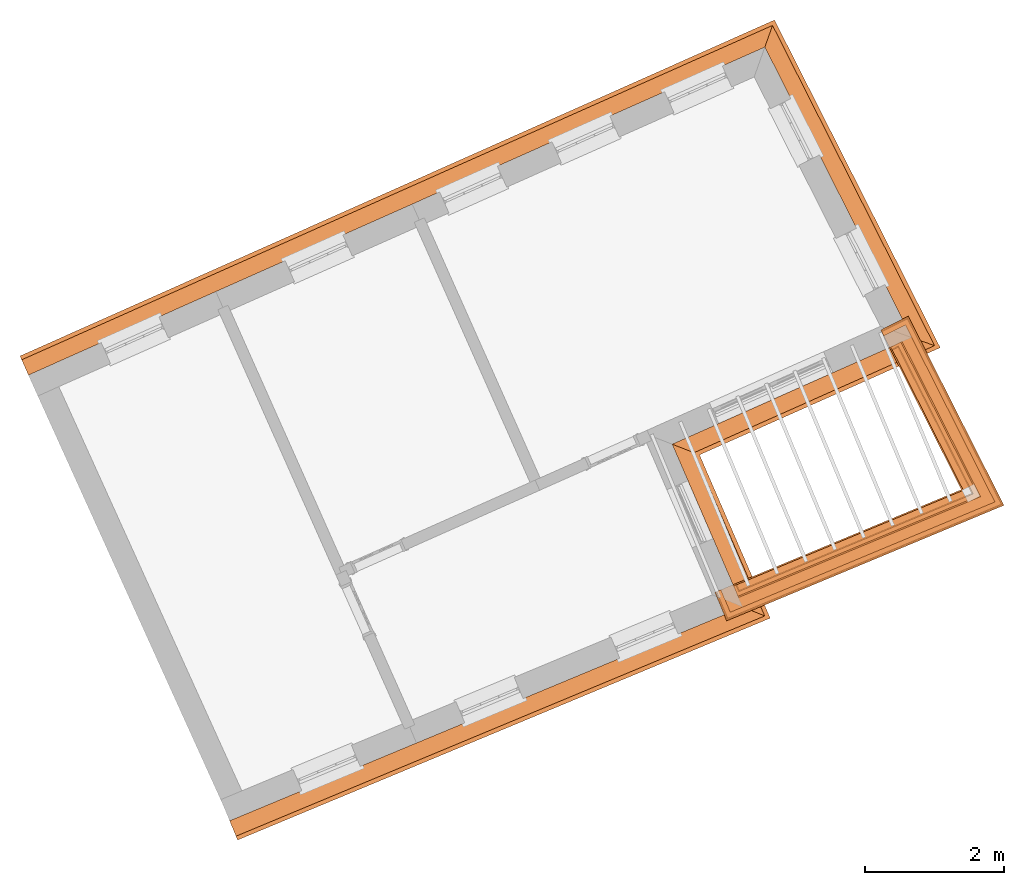
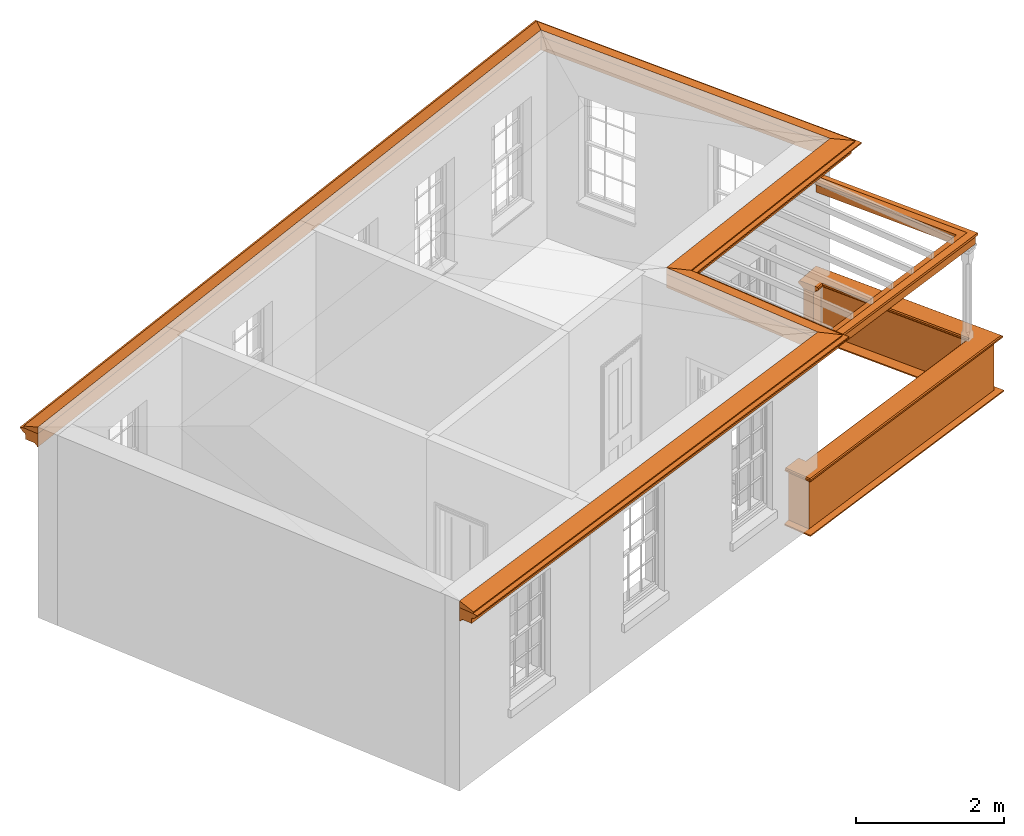
# One storey, part 9 of 10: 7 proxies.
"""IFC2X3 building model written with IfcOpenShell, lengths in metres."""

import ifcopenshell
import ifcopenshell.guid

model = None  # the IFC model being written
_history = None  # IfcOwnerHistory: only IFC2X3 demands one
_inside = {}  # id of a spatial element -> (the spatial element, [elements in it])
_under = {}  # id of a project, library or spatial element -> (it, [spatial elements below it])
_declared = {}  # id of a project -> (the project, [libraries it declares])
_typed = {}  # id of a type object -> (the type object, [elements of that type])
_made_of = {}  # id of a material, layer set ... -> (it, [elements and type objects made of it])


def new_model(schema):
    """Start an empty IFC model of exactly this schema.

    Asked for "IFC4X3", IfcOpenShell would pick the latest addendum, in which some entities
    have other attributes; the version numbers below select the first issue.
    IFC2X3 requires an IfcOwnerHistory on every rooted entity: one is made here for all.
    """
    global model, _history
    if schema == "IFC4X3":
        model = ifcopenshell.file(schema_version=(4, 3, 0, 0))
    else:
        model = ifcopenshell.file(schema=schema)
    _inside.clear()
    _under.clear()
    _declared.clear()
    _typed.clear()
    _made_of.clear()
    _history = None
    if model.schema == "IFC2X3":
        org = make("IfcOrganization", Name="unknown")
        user = make(
            "IfcPersonAndOrganization",
            ThePerson=make("IfcPerson", FamilyName="unknown"),
            TheOrganization=org,
        )
        app = make(
            "IfcApplication",
            ApplicationDeveloper=org,
            Version="unknown",
            ApplicationFullName="unknown",
            ApplicationIdentifier="unknown",
        )
        _history = make(
            "IfcOwnerHistory",
            OwningUser=user,
            OwningApplication=app,
            ChangeAction="ADDED",
            CreationDate=0,
        )
    return model


def make(cls, **values):
    """One entity of the class cls with the attributes given. An attribute that is None is left unset."""
    return model.create_entity(
        cls, **{name: value for name, value in values.items() if value is not None}
    )


def entity(cls, *values):
    """Any entity or typed value of the class cls, its attributes in the order of the schema. None: left unset."""
    e = model.create_entity(cls)
    for i, value in enumerate(values):
        if value is not None:
            e[i] = value
    return e


def rooted(cls, **values):
    """An entity with a GlobalId (a new one), such as an element, a storey or a relation."""
    return make(cls, GlobalId=ifcopenshell.guid.new(), OwnerHistory=_history, **values)


def si_unit(unit_type, name, prefix=None):
    """IfcSIUnit, for example si_unit("LENGTHUNIT", "METRE", prefix="MILLI")."""
    return make("IfcSIUnit", UnitType=unit_type, Prefix=prefix, Name=name)


def assignment(units):
    """IfcUnitAssignment: the units of a project."""
    return None if units is None else make("IfcUnitAssignment", Units=units)


def point(xyz):
    """IfcCartesianPoint."""
    return None if xyz is None else make("IfcCartesianPoint", Coordinates=xyz)


def direction(xyz):
    """IfcDirection."""
    return None if xyz is None else make("IfcDirection", DirectionRatios=xyz)


def frame(location, z_axis=None, x_axis=None):
    """IfcAxis2Placement3D, a coordinate frame: its origin and axes. An axis left out is left unset."""
    return make(
        "IfcAxis2Placement3D",
        Location=point(location),
        Axis=direction(z_axis),
        RefDirection=direction(x_axis),
    )


def origin():
    """The frame at (0, 0, 0) with its axes left unset."""
    return frame((0.0, 0.0, 0.0))


def place(relative_to, where):
    """IfcLocalPlacement: puts the frame where relative to a parent placement (None: the world)."""
    return make(
        "IfcLocalPlacement", PlacementRelTo=relative_to, RelativePlacement=where
    )


def context(
    kind, dimensions, precision=None, world=None, true_north=None, identifier=None
):
    """IfcGeometricRepresentationContext, for example the 3D "Model" context."""
    return make(
        "IfcGeometricRepresentationContext",
        ContextIdentifier=identifier,
        ContextType=kind,
        CoordinateSpaceDimension=dimensions,
        Precision=precision,
        WorldCoordinateSystem=world,
        TrueNorth=true_north,
    )


def subcontext(parent, identifier, kind, view, scale=None):
    """IfcGeometricRepresentationSubContext, for example "Body" below "Model"."""
    return make(
        "IfcGeometricRepresentationSubContext",
        ContextIdentifier=identifier,
        ContextType=kind,
        ParentContext=parent,
        TargetScale=scale,
        TargetView=view,
    )


def project(units=None, contexts=None):
    """IfcProject with its units and contexts."""
    return rooted(
        "IfcProject",
        Name="project",
        RepresentationContexts=contexts,
        UnitsInContext=assignment(units),
    )


def spatial(cls, under=None, at=None, **own):
    """A site, building, storey or space (cls), placed at a placement, below another one or the project."""
    s = rooted(cls, ObjectPlacement=at, **own)
    if under is not None:
        _under.setdefault(under.id(), (under, []))[1].append(s)
    return s


def shape(context_of_items, identifier, shape_type, items):
    """IfcShapeRepresentation: the items that make up one representation, for example the "Body"."""
    return make(
        "IfcShapeRepresentation",
        ContextOfItems=context_of_items,
        RepresentationIdentifier=identifier,
        RepresentationType=shape_type,
        Items=items,
    )


def made_of(thing, what):
    """Note that an element or type object is made of a material, layer set ...; save() writes the relation."""
    if what is not None:
        _made_of.setdefault(what.id(), (what, []))[1].append(thing)
    return thing


def element(
    cls,
    number,
    at=None,
    inside=None,
    cuts=None,
    type_object=None,
    material=None,
    context=None,
    identifier="Body",
    shape_type=None,
    held_by="IfcProductDefinitionShape",
    body=None,
    shapes=None,
    **own,
):
    """One element of the class cls, such as IfcWall. Its Tag is "e" and its number.

    at: its placement. inside: the storey or other place that contains it. cuts: it is an
    opening in that element (IfcRelVoidsElement). A single representation is given by context,
    identifier, shape_type and body (its items); several are given by shapes. held_by: the class
    of the entity that holds the representations. save() writes the other relations.
    """
    e = rooted(cls, Tag="e%d" % number, ObjectPlacement=at, **own)
    if body is not None:
        shapes = [shape(context, identifier, shape_type, body)]
    if shapes is not None:
        e.Representation = make(held_by, Representations=shapes)
    if inside is not None:
        _inside.setdefault(inside.id(), (inside, []))[1].append(e)
    if cuts is not None:
        rooted(
            "IfcRelVoidsElement", RelatingBuildingElement=cuts, RelatedOpeningElement=e
        )
    if type_object is not None:
        _typed.setdefault(type_object.id(), (type_object, []))[1].append(e)
    return made_of(e, material)


def aggregate(whole, parts):
    """IfcRelAggregates: a whole, such as a stair, and the parts it consists of."""
    return rooted("IfcRelAggregates", RelatingObject=whole, RelatedObjects=parts)


def save(model, path):
    """Write the relations noted so far, then the file.

    IfcRelAggregates (storeys below a building ...), IfcRelContainedInSpatialStructure (elements
    in a storey), IfcRelDefinesByType, IfcRelAssociatesMaterial and IfcRelDeclares: one each for
    every whole, place, type object, material and project.
    """
    for whole, parts in _under.values():
        aggregate(whole, parts)
    for where, things in _inside.values():
        rooted(
            "IfcRelContainedInSpatialStructure",
            RelatedElements=things,
            RelatingStructure=where,
        )
    for kind, things in _typed.values():
        rooted("IfcRelDefinesByType", RelatedObjects=things, RelatingType=kind)
    for what, things in _made_of.values():
        rooted("IfcRelAssociatesMaterial", RelatedObjects=things, RelatingMaterial=what)
    for by, libraries in _declared.values():
        rooted("IfcRelDeclares", RelatingContext=by, RelatedDefinitions=libraries)
    model.write(path)


model = new_model("IFC2X3")

# Units and contexts
model_context = context("Model", 3, world=origin())
body_context = subcontext(model_context, "Body", "Model", "MODEL_VIEW")
ifc_project = project(units=[si_unit("PLANEANGLEUNIT", "RADIAN"), si_unit("MASSUNIT", "GRAM", prefix="KILO"), si_unit("FORCEUNIT", "NEWTON", prefix="KILO"), si_unit("LENGTHUNIT", "METRE")], contexts=[model_context])

# Site, building, storey
site_placement = place(None, origin())
site = spatial("IfcSite", under=ifc_project, at=site_placement, CompositionType="ELEMENT")
building_placement = place(None, origin())
building = spatial("IfcBuilding", under=site, at=building_placement, Name="Building plot-1", CompositionType="ELEMENT")
storey_placement = place(None, frame((0.0, 0.0, 8.45)))
storey = spatial("IfcBuildingStorey", under=building, at=storey_placement, Name="Floor 2", CompositionType="ELEMENT", Elevation=8.45)

# Proxies
proxy_1_placement = place(storey_placement, frame((0.0, 0.0, 3.15)))
axis2_placement3_d_1 = entity("IfcAxis2Placement3D", entity("IfcCartesianPoint", [0.0, 0.0, 0.0]))
element("IfcBuildingElementProxy", 1, at=proxy_1_placement, inside=storey, Name="eaves", CompositionType="ELEMENT", context=body_context, shape_type="SweptSolid", held_by="IfcProductRepresentation", body=[
    entity("IfcSurfaceCurveSweptAreaSolid", entity("IfcArbitraryClosedProfileDef", "AREA", None, entity("IfcPolyline", [entity("IfcCartesianPoint", [-0.11, 0.25]), entity("IfcCartesianPoint", [-0.33, 0.25]), entity("IfcCartesianPoint", [-0.33, 0.265]), entity("IfcCartesianPoint", [-0.318, 0.268]), entity("IfcCartesianPoint", [-0.309, 0.274]), entity("IfcCartesianPoint", [-0.303, 0.283]), entity("IfcCartesianPoint", [-0.3, 0.295]), entity("IfcCartesianPoint", [-0.285, 0.295]), entity("IfcCartesianPoint", [-0.285, 0.455]), entity("IfcCartesianPoint", [-0.205, 0.455]), entity("IfcCartesianPoint", [-0.205, 0.47]), entity("IfcCartesianPoint", [-0.19, 0.47]), entity("IfcCartesianPoint", [-0.189, 0.483]), entity("IfcCartesianPoint", [-0.186, 0.494]), entity("IfcCartesianPoint", [-0.179, 0.506]), entity("IfcCartesianPoint", [-0.17, 0.514]), entity("IfcCartesianPoint", [-0.16, 0.52]), entity("IfcCartesianPoint", [-0.149, 0.529]), entity("IfcCartesianPoint", [-0.143, 0.539]), entity("IfcCartesianPoint", [-0.14, 0.55]), entity("IfcCartesianPoint", [-0.12, 0.55]), entity("IfcCartesianPoint", [-0.11, 0.48]), entity("IfcCartesianPoint", [-0.11, 0.25])])), axis2_placement3_d_1, entity("IfcPolyline", [entity("IfcCartesianPoint", [21.5864704942172, 40.1998432256343]), entity("IfcCartesianPoint", [28.7343063231357, 43.177795396212]), entity("IfcCartesianPoint", [27.7222293046875, 45.5152255067765]), entity("IfcCartesianPoint", [31.1551869967516, 47.0441118465575]), entity("IfcCartesianPoint", [29.26756691189, 50.7759222940703]), entity("IfcCartesianPoint", [18.8898048741042, 46.154129647529])]), 0.0, 1.0, entity("IfcPlane", axis2_placement3_d_1)),
])
proxy_2_placement = place(storey_placement, frame((0.0, 0.0, 3.15)))
axis2_placement3_d_2 = entity("IfcAxis2Placement3D", entity("IfcCartesianPoint", [0.0, 0.0, 0.0]))
element("IfcBuildingElementProxy", 2, at=proxy_2_placement, inside=storey, Name="eaves", CompositionType="ELEMENT", context=body_context, shape_type="SweptSolid", held_by="IfcProductRepresentation", body=[
    entity("IfcSurfaceCurveSweptAreaSolid", entity("IfcArbitraryClosedProfileDef", "AREA", None, entity("IfcPolyline", [entity("IfcCartesianPoint", [-0.11, 0.25]), entity("IfcCartesianPoint", [-0.11, 0.48]), entity("IfcCartesianPoint", [-0.08, 0.49]), entity("IfcCartesianPoint", [0.0, 0.25]), entity("IfcCartesianPoint", [-0.11, 0.25])])), axis2_placement3_d_2, entity("IfcPolyline", [entity("IfcCartesianPoint", [21.5864704942172, 40.1998432256343]), entity("IfcCartesianPoint", [28.7343063231357, 43.177795396212]), entity("IfcCartesianPoint", [27.7222293046875, 45.5152255067765]), entity("IfcCartesianPoint", [31.1551869967516, 47.0441118465575]), entity("IfcCartesianPoint", [29.26756691189, 50.7759222940703]), entity("IfcCartesianPoint", [18.8898048741042, 46.154129647529])]), 0.0, 1.0, entity("IfcPlane", axis2_placement3_d_2)),
])
proxy_3_placement = place(storey_placement, origin())
axis2_placement3_d_3 = entity("IfcAxis2Placement3D", entity("IfcCartesianPoint", [0.0, 0.0, 0.0]))
element("IfcBuildingElementProxy", 3, at=proxy_3_placement, inside=storey, Name="parapet", CompositionType="ELEMENT", context=body_context, shape_type="SweptSolid", held_by="IfcProductRepresentation", body=[
    entity("IfcSurfaceCurveSweptAreaSolid", entity("IfcArbitraryClosedProfileDef", "AREA", None, entity("IfcPolyline", [entity("IfcCartesianPoint", [0.0, 0.25]), entity("IfcCartesianPoint", [0.795, 0.25]), entity("IfcCartesianPoint", [0.795, 0.09]), entity("IfcCartesianPoint", [0.02, 0.09]), entity("IfcCartesianPoint", [0.02, -0.08]), entity("IfcCartesianPoint", [0.0, -0.08]), entity("IfcCartesianPoint", [0.0, 0.25])])), axis2_placement3_d_3, entity("IfcPolyline", [entity("IfcCartesianPoint", [28.9820065175484, 43.3893246227692]), entity("IfcCartesianPoint", [29.0204646144301, 43.2970154965452]), entity("IfcCartesianPoint", [32.3490806671408, 44.6837932061123]), entity("IfcCartesianPoint", [31.2951094313926, 46.7674862651589]), entity("IfcCartesianPoint", [31.2058753728769, 46.7223499959198])]), 0.0, 1.0, entity("IfcPlane", axis2_placement3_d_3)),
])
proxy_4_placement = place(storey_placement, origin())
axis2_placement3_d_4 = entity("IfcAxis2Placement3D", entity("IfcCartesianPoint", [0.0, 0.0, 0.0]))
element("IfcBuildingElementProxy", 4, at=proxy_4_placement, inside=storey, Name="parapet", CompositionType="ELEMENT", context=body_context, shape_type="SweptSolid", held_by="IfcProductRepresentation", body=[
    entity("IfcSurfaceCurveSweptAreaSolid", entity("IfcArbitraryClosedProfileDef", "AREA", None, entity("IfcPolyline", [entity("IfcCartesianPoint", [0.795, 0.265]), entity("IfcCartesianPoint", [0.807, 0.268]), entity("IfcCartesianPoint", [0.816, 0.274]), entity("IfcCartesianPoint", [0.822, 0.283]), entity("IfcCartesianPoint", [0.825, 0.295]), entity("IfcCartesianPoint", [0.84, 0.295]), entity("IfcCartesianPoint", [0.84, 0.305]), entity("IfcCartesianPoint", [0.842, 0.317]), entity("IfcCartesianPoint", [0.849, 0.326]), entity("IfcCartesianPoint", [0.858, 0.333]), entity("IfcCartesianPoint", [0.87, 0.335]), entity("IfcCartesianPoint", [0.882, 0.333]), entity("IfcCartesianPoint", [0.891, 0.326]), entity("IfcCartesianPoint", [0.898, 0.317]), entity("IfcCartesianPoint", [0.9, 0.305]), entity("IfcCartesianPoint", [0.9, 0.035]), entity("IfcCartesianPoint", [0.898, 0.023]), entity("IfcCartesianPoint", [0.891, 0.014]), entity("IfcCartesianPoint", [0.882, 0.007]), entity("IfcCartesianPoint", [0.87, 0.005]), entity("IfcCartesianPoint", [0.858, 0.007]), entity("IfcCartesianPoint", [0.849, 0.014]), entity("IfcCartesianPoint", [0.842, 0.023]), entity("IfcCartesianPoint", [0.84, 0.035]), entity("IfcCartesianPoint", [0.84, 0.045]), entity("IfcCartesianPoint", [0.825, 0.045]), entity("IfcCartesianPoint", [0.822, 0.057]), entity("IfcCartesianPoint", [0.816, 0.066]), entity("IfcCartesianPoint", [0.807, 0.072]), entity("IfcCartesianPoint", [0.795, 0.075]), entity("IfcCartesianPoint", [0.795, 0.265])])), axis2_placement3_d_4, entity("IfcPolyline", [entity("IfcCartesianPoint", [28.9820065175484, 43.3893246227692]), entity("IfcCartesianPoint", [29.0204646144301, 43.2970154965452]), entity("IfcCartesianPoint", [32.3490806671408, 44.6837932061123]), entity("IfcCartesianPoint", [31.2951094313926, 46.7674862651589]), entity("IfcCartesianPoint", [31.2058753728769, 46.7223499959198])]), 0.0, 1.0, entity("IfcPlane", axis2_placement3_d_4)),
])
proxy_5_placement = place(storey_placement, origin())
axis2_placement3_d_5 = entity("IfcAxis2Placement3D", entity("IfcCartesianPoint", [0.0, 0.0, 0.0]))
element("IfcBuildingElementProxy", 5, at=proxy_5_placement, inside=storey, Name="parapet", CompositionType="ELEMENT", context=body_context, shape_type="SweptSolid", held_by="IfcProductRepresentation", body=[
    entity("IfcSurfaceCurveSweptAreaSolid", entity("IfcArbitraryClosedProfileDef", "AREA", None, entity("IfcPolyline", [entity("IfcCartesianPoint", [-0.1, 0.25]), entity("IfcCartesianPoint", [-0.1, 0.265]), entity("IfcCartesianPoint", [-0.085, 0.265]), entity("IfcCartesianPoint", [-0.084, 0.278]), entity("IfcCartesianPoint", [-0.081, 0.289]), entity("IfcCartesianPoint", [-0.074, 0.301]), entity("IfcCartesianPoint", [-0.065, 0.309]), entity("IfcCartesianPoint", [-0.055, 0.315]), entity("IfcCartesianPoint", [-0.044, 0.324]), entity("IfcCartesianPoint", [-0.038, 0.334]), entity("IfcCartesianPoint", [-0.035, 0.345]), entity("IfcCartesianPoint", [-0.015, 0.345]), entity("IfcCartesianPoint", [0.0, 0.25]), entity("IfcCartesianPoint", [-0.1, 0.25])])), axis2_placement3_d_5, entity("IfcPolyline", [entity("IfcCartesianPoint", [28.9820065175484, 43.3893246227692]), entity("IfcCartesianPoint", [29.0204646144301, 43.2970154965452]), entity("IfcCartesianPoint", [32.3490806671408, 44.6837932061123]), entity("IfcCartesianPoint", [31.2951094313926, 46.7674862651589]), entity("IfcCartesianPoint", [31.2058753728769, 46.7223499959198])]), 0.0, 1.0, entity("IfcPlane", axis2_placement3_d_5)),
])
proxy_6_placement = place(storey_placement, frame((0.0, 0.0, 3.15)))
axis2_placement3_d_6 = entity("IfcAxis2Placement3D", entity("IfcCartesianPoint", [0.0, 0.0, 0.0]))
element("IfcBuildingElementProxy", 6, at=proxy_6_placement, inside=storey, Name="pergola beam", CompositionType="ELEMENT", context=body_context, shape_type="SweptSolid", held_by="IfcProductRepresentation", body=[
    entity("IfcSurfaceCurveSweptAreaSolid", entity("IfcArbitraryClosedProfileDef", "AREA", None, entity("IfcPolyline", [entity("IfcCartesianPoint", [-0.7, -0.08]), entity("IfcCartesianPoint", [-0.7, 0.08]), entity("IfcCartesianPoint", [-0.56, 0.08]), entity("IfcCartesianPoint", [-0.56, -0.08]), entity("IfcCartesianPoint", [-0.7, -0.08])])), axis2_placement3_d_6, entity("IfcPolyline", [entity("IfcCartesianPoint", [28.9650791386957, 43.2739406384162]), entity("IfcCartesianPoint", [32.3490806671408, 44.6837932061123]), entity("IfcCartesianPoint", [31.2680276698492, 46.8210267002683])]), 0.0, 1.0, entity("IfcPlane", axis2_placement3_d_6)),
])
proxy_7_placement = place(storey_placement, frame((0.0, 0.0, 3.15)))
axis2_placement3_d_7 = entity("IfcAxis2Placement3D", entity("IfcCartesianPoint", [0.0, 0.0, 0.0]))
element("IfcBuildingElementProxy", 7, at=proxy_7_placement, inside=storey, Name="pergola beam", CompositionType="ELEMENT", context=body_context, shape_type="SweptSolid", held_by="IfcProductRepresentation", body=[
    entity("IfcSurfaceCurveSweptAreaSolid", entity("IfcArbitraryClosedProfileDef", "AREA", None, entity("IfcPolyline", [entity("IfcCartesianPoint", [-0.5, 0.0]), entity("IfcCartesianPoint", [-0.52, -0.1]), entity("IfcCartesianPoint", [-0.56, -0.1]), entity("IfcCartesianPoint", [-0.56, 0.1]), entity("IfcCartesianPoint", [-0.52, 0.1]), entity("IfcCartesianPoint", [-0.5, 0.0])])), axis2_placement3_d_7, entity("IfcPolyline", [entity("IfcCartesianPoint", [28.9650791386957, 43.2739406384162]), entity("IfcCartesianPoint", [32.3490806671408, 44.6837932061123]), entity("IfcCartesianPoint", [31.2680276698492, 46.8210267002683])]), 0.0, 1.0, entity("IfcPlane", axis2_placement3_d_7)),
])

save(model, "model.ifc")
